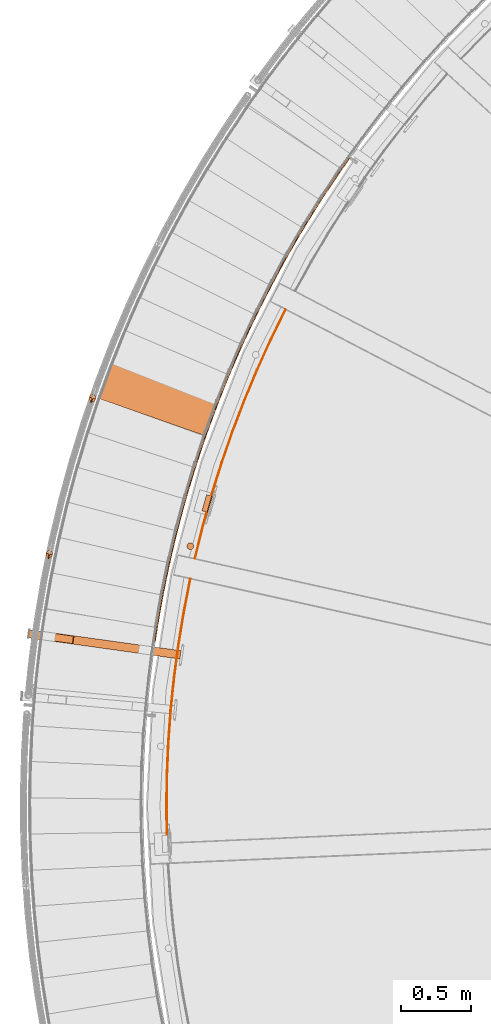
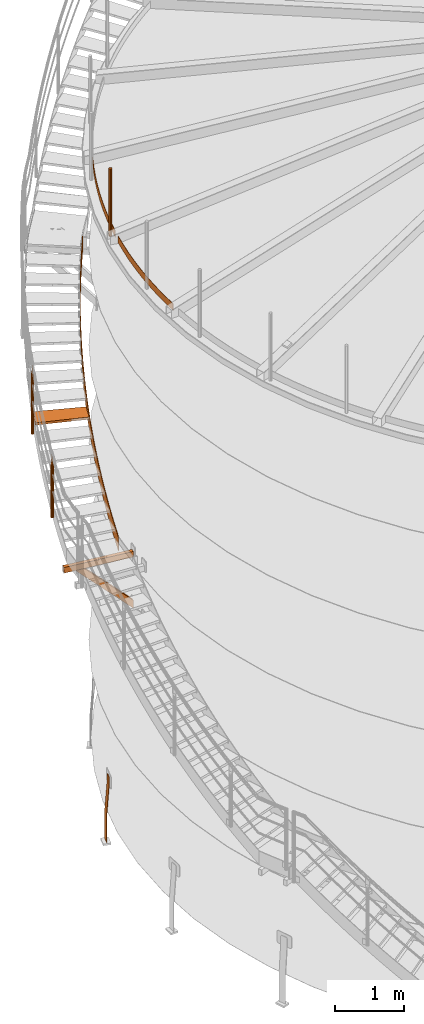
# One storey, part 25 of 126: 10 proxies.
"""IFC2X3 building model written with IfcOpenShell, lengths in millimetres."""

from ifc_helpers import new_model, si_unit, origin, origin_with_axes, place, context, project, spatial, faceted_brep, material, element, save


model = new_model("IFC2X3")

# Units and contexts
context_of_model_1 = context(None, 3, precision=0.1, world=origin())
context_of_model_2 = context(None, 3, precision=0.1, world=origin())
ifc_project = project(units=[si_unit("LENGTHUNIT", "METRE", prefix="MILLI"), si_unit("AREAUNIT", "SQUARE_METRE", prefix="CENTI"), si_unit("VOLUMEUNIT", "CUBIC_METRE", prefix="CENTI"), si_unit("MASSUNIT", "GRAM", prefix="KILO")], contexts=[context_of_model_1, context_of_model_2])

# Site, building, storey
site_placement = place(None, origin_with_axes())
site = spatial("IfcSite", under=ifc_project, at=site_placement, CompositionType="ELEMENT")
building_placement = place(site_placement, origin_with_axes())
building = spatial("IfcBuilding", under=site, at=building_placement, CompositionType="ELEMENT")
storey_placement = place(building_placement, origin_with_axes())
storey = spatial("IfcBuildingStorey", under=building, at=storey_placement, CompositionType="ELEMENT")

# Proxies
ifc_material_1 = material(Name="HOLZ")
proxy_1_placement = place(storey_placement, origin_with_axes())
element("IfcBuildingElementProxy", 1, at=proxy_1_placement, inside=storey, material=ifc_material_1, context=context_of_model_2, shape_type="Brep", body=[
    faceted_brep([(-215.7659, 11192.239, 6755.0438), (-225.2447, 11167.682, 6755.0438), (-234.6502, 11143.097, 6755.0438), (-243.9822, 11118.484, 6755.0438), (-253.2407, 11093.842, 6755.0438), (-262.4256, 11069.174, 6755.0438), (-271.5368, 11044.478, 6755.0438), (-280.5742, 11019.755, 6755.0438), (-289.5378, 10995.005, 6755.0438), (-298.4274, 10970.228, 6755.0438), (-307.2431, 10945.425, 6755.0438), (-315.9846, 10920.596, 6755.0438), (439.01, 10656.053, 6755.0438), (447.8478, 10681.142, 6755.0438), (456.7688, 10706.202, 6755.0438), (465.7729, 10731.232, 6755.0438), (474.86, 10756.232, 6755.0438), (484.03, 10781.202, 6755.0438), (493.2828, 10806.141, 6755.0438), (502.6183, 10831.049, 6755.0438), (512.0364, 10855.927, 6755.0438), (521.537, 10880.773, 6755.0438), (531.1199, 10905.587, 6755.0438), (-215.7659, 11192.239, 6715.0438), (531.1199, 10905.587, 6715.0438), (521.537, 10880.773, 6715.0438), (512.0364, 10855.927, 6715.0438), (502.6183, 10831.049, 6715.0438), (493.2828, 10806.141, 6715.0438), (484.03, 10781.202, 6715.0438), (474.86, 10756.232, 6715.0438), (465.7729, 10731.232, 6715.0438), (456.7688, 10706.202, 6715.0438), (447.8478, 10681.142, 6715.0438), (439.01, 10656.053, 6715.0438), (-315.9846, 10920.596, 6715.0438), (-307.2431, 10945.425, 6715.0438), (-298.4274, 10970.228, 6715.0438), (-289.5378, 10995.005, 6715.0438), (-280.5742, 11019.755, 6715.0438), (-271.5368, 11044.478, 6715.0438), (-262.4256, 11069.174, 6715.0438), (-253.2407, 11093.842, 6715.0438), (-243.9822, 11118.484, 6715.0438), (-234.6502, 11143.097, 6715.0438), (-225.2447, 11167.682, 6715.0438)], [[[0, 1, 2, 3, 4, 5, 6, 7, 8, 9, 10, 11, 12, 13, 14, 15, 16, 17, 18, 19, 20, 21, 22]], [[23, 24, 25, 26, 27, 28, 29, 30, 31, 32, 33, 34, 35, 36, 37, 38, 39, 40, 41, 42, 43, 44, 45]], [[0, 23, 45, 1]], [[1, 45, 44, 2]], [[2, 44, 43, 3]], [[3, 43, 42, 4]], [[4, 42, 41, 5]], [[5, 41, 40, 6]], [[6, 40, 39, 7]], [[7, 39, 38, 8]], [[8, 38, 37, 9]], [[9, 37, 36, 10]], [[10, 36, 35, 11]], [[11, 35, 34, 12]], [[12, 34, 33, 13]], [[13, 33, 32, 14]], [[14, 32, 31, 15]], [[15, 31, 30, 16]], [[16, 30, 29, 17]], [[17, 29, 28, 18]], [[18, 28, 27, 19]], [[19, 27, 26, 20]], [[20, 26, 25, 21]], [[21, 25, 24, 22]], [[22, 24, 23, 0]]]),
])
ifc_material_2 = material(Name="S235JRG2")
proxy_2_placement = place(storey_placement, origin_with_axes())
element("IfcBuildingElementProxy", 2, at=proxy_2_placement, inside=storey, material=ifc_material_2, context=context_of_model_2, shape_type="Brep", body=[
    faceted_brep([(-821.3165, 9206.5283, 5292.55), (-821.3165, 9206.5283, 5392.55), (-813.0231, 9265.9524, 5392.55), (-813.0231, 9265.9524, 5292.55), (-820.9018, 9209.4995, 5295.55), (-813.4378, 9262.9812, 5295.55), (-813.4378, 9262.9812, 5389.55), (-820.9018, 9209.4995, 5389.55), (271.1421, 9114.644, 5292.55), (262.8487, 9055.2199, 5292.55), (271.1421, 9114.644, 5392.55), (262.8487, 9055.2199, 5392.55), (263.2634, 9058.1911, 5389.55), (263.2634, 9058.1911, 5295.55), (270.7274, 9111.6728, 5389.55), (270.7274, 9111.6728, 5295.55)], [[[0, 1, 2, 3], [4, 5, 6, 7]], [[0, 3, 8, 9]], [[2, 10, 8, 3]], [[1, 11, 10, 2]], [[0, 9, 11, 1]], [[4, 7, 12, 13]], [[6, 14, 12, 7]], [[5, 15, 14, 6]], [[4, 13, 15, 5]], [[9, 8, 10, 11], [12, 14, 15, 13]]]),
])
proxy_3_placement = place(storey_placement, origin_with_axes())
element("IfcBuildingElementProxy", 3, at=proxy_3_placement, inside=storey, material=ifc_material_2, context=context_of_model_2, shape_type="Brep", body=[
    faceted_brep([(-643.7481, 9181.7465, 5292.55), (-635.4548, 9241.1706, 5292.55), (271.1421, 9114.644, 4377.1666), (262.8487, 9055.2199, 4377.1666), (-495.3909, 9221.6229, 5292.55), (271.1421, 9114.644, 4518.5879), (-503.6842, 9162.1989, 5292.55), (262.8487, 9055.2199, 4518.5879), (-639.1315, 9184.1313, 5292.55), (-507.4715, 9165.7565, 5292.55), (263.2634, 9058.1911, 4514.3453), (263.2634, 9058.1911, 4381.4092), (-500.0075, 9219.2382, 5292.55), (270.7274, 9111.6728, 4514.3453), (-631.6675, 9237.6129, 5292.55), (270.7274, 9111.6728, 4381.4092)], [[[0, 1, 2, 3]], [[1, 4, 5, 2]], [[4, 6, 7, 5]], [[0, 3, 7, 6]], [[8, 9, 10, 11]], [[9, 12, 13, 10]], [[12, 14, 15, 13]], [[8, 11, 15, 14]], [[1, 0, 6, 4], [8, 14, 12, 9]], [[3, 2, 5, 7], [10, 13, 15, 11]]]),
])
ifc_material_3 = material(Name="STAHL")
proxy_4_placement = place(storey_placement, origin_with_axes())
element("IfcBuildingElementProxy", 4, at=proxy_4_placement, inside=storey, material=ifc_material_3, Name="profile", context=context_of_model_2, shape_type="Brep", body=[
    faceted_brep([(489.3, 10219.0, 651.1), (488.6, 10216.6, 654.1), (496.3, 10214.4, 654.1), (497.0, 10216.8, 651.1), (497.5, 10218.6, 647.7), (489.8, 10220.8, 647.7), (497.8, 10219.7, 643.9), (490.1, 10221.9, 643.9), (497.9, 10220.0, 640.0), (497.9, 10220.0, 540.0), (461.4, 10230.5, 0.0), (461.4, 10230.5, -500.0), (453.7, 10232.7, -500.0), (453.7, 10232.7, 0.0), (490.3, 10222.2, 540.0), (490.3, 10222.2, 640.0), (466.5, 10110.3, 654.1), (458.8, 10112.5, 654.1), (458.1, 10110.1, 651.1), (465.8, 10107.9, 651.1), (465.3, 10106.1, 647.7), (457.6, 10108.3, 647.7), (465.0, 10105.0, 643.9), (457.3, 10107.3, 643.9), (464.9, 10104.7, 640.0), (457.2, 10106.9, 640.0), (457.2, 10106.9, 540.0), (420.6, 10117.4, 0.0), (420.6, 10117.4, -500.0), (428.3, 10115.2, -500.0), (428.3, 10115.2, 0.0), (464.9, 10104.7, 540.0), (469.3, 10120.2, 659.6), (470.4, 10123.9, 660.0), (492.4, 10200.8, 660.0), (493.5, 10204.6, 659.6), (485.8, 10206.8, 659.6), (484.7, 10203.0, 660.0), (462.7, 10126.1, 660.0), (461.6, 10122.4, 659.6), (460.6, 10118.8, 658.5), (468.3, 10116.5, 658.5), (459.6, 10115.4, 656.6), (467.3, 10113.2, 656.6), (494.5, 10208.2, 658.5), (486.9, 10210.4, 658.5), (495.5, 10211.5, 656.6), (487.8, 10213.7, 656.6)], [[[0, 1, 2, 3]], [[0, 3, 4, 5]], [[5, 4, 6, 7]], [[6, 8, 9, 10, 11, 12, 13, 14, 15, 7]], [[16, 17, 18, 19]], [[20, 19, 18, 21]], [[22, 20, 21, 23]], [[24, 22, 23, 25, 26, 27, 28, 29, 30, 31]], [[32, 33, 34, 35, 36, 37, 38, 39]], [[32, 39, 40, 41]], [[41, 40, 42, 43]], [[43, 42, 17, 16]], [[36, 35, 44, 45]], [[45, 44, 46, 47]], [[47, 46, 2, 1]], [[26, 25, 23, 21, 18, 17, 42, 40, 39, 38, 37, 36, 45, 47, 1, 0, 5, 7, 15, 14, 13, 12, 28, 27]], [[24, 31, 30, 29, 11, 10, 9, 8, 6, 4, 3, 2, 46, 44, 35, 34, 33, 32, 41, 43, 16, 19, 20, 22]], [[28, 12, 11, 29]]]),
])
proxy_5_placement = place(storey_placement, origin_with_axes())
element("IfcBuildingElementProxy", 5, at=proxy_5_placement, inside=storey, material=ifc_material_3, Name="profile", context=context_of_model_2, shape_type="Brep", body=[
    faceted_brep([(357.5, 9876.0, 11706.0), (357.5, 9876.0, 10506.0), (353.9, 9880.6, 10506.0), (353.9, 9880.6, 11706.0), (349.3, 9884.1, 10506.0), (349.3, 9884.1, 11706.0), (344.0, 9886.5, 10506.0), (344.0, 9886.5, 11706.0), (338.2, 9887.5, 10506.0), (338.2, 9887.5, 11706.0), (332.4, 9887.1, 10506.0), (332.4, 9887.1, 11706.0), (326.9, 9885.3, 10506.0), (326.9, 9885.3, 11706.0), (321.9, 9882.2, 10506.0), (321.9, 9882.2, 11706.0), (317.8, 9878.1, 10506.0), (317.8, 9878.1, 11706.0), (314.9, 9873.1, 10506.0), (314.9, 9873.1, 11706.0), (313.2, 9867.5, 10506.0), (313.2, 9867.5, 11706.0), (312.9, 9861.7, 10506.0), (312.9, 9861.7, 11706.0), (314.0, 9856.0, 10506.0), (314.0, 9856.0, 11706.0), (316.4, 9850.7, 10506.0), (316.4, 9850.7, 11706.0), (320.0, 9846.1, 11706.0), (320.0, 9846.1, 10506.0), (324.6, 9842.6, 11706.0), (324.6, 9842.6, 10506.0), (330.0, 9840.2, 11706.0), (330.0, 9840.2, 10506.0), (335.7, 9839.2, 11706.0), (335.7, 9839.2, 10506.0), (341.5, 9839.6, 11706.0), (341.5, 9839.6, 10506.0), (347.1, 9841.4, 11706.0), (347.1, 9841.4, 10506.0), (352.0, 9844.5, 11706.0), (352.0, 9844.5, 10506.0), (356.1, 9848.6, 11706.0), (356.1, 9848.6, 10506.0), (359.1, 9853.6, 11706.0), (359.1, 9853.6, 10506.0), (360.8, 9859.2, 11706.0), (360.8, 9859.2, 10506.0), (361.1, 9865.0, 11706.0), (361.1, 9865.0, 10506.0), (360.0, 9870.7, 11706.0), (360.0, 9870.7, 10506.0)], [[[0, 1, 2, 3]], [[3, 2, 4, 5]], [[5, 4, 6, 7]], [[7, 6, 8, 9]], [[9, 8, 10, 11]], [[11, 10, 12, 13]], [[13, 12, 14, 15]], [[15, 14, 16, 17]], [[17, 16, 18, 19]], [[19, 18, 20, 21]], [[21, 20, 22, 23]], [[23, 22, 24, 25]], [[25, 24, 26, 27]], [[28, 27, 26, 29]], [[30, 28, 29, 31]], [[32, 30, 31, 33]], [[34, 32, 33, 35]], [[36, 34, 35, 37]], [[38, 36, 37, 39]], [[40, 38, 39, 41]], [[42, 40, 41, 43]], [[44, 42, 43, 45]], [[46, 44, 45, 47]], [[48, 46, 47, 49]], [[50, 48, 49, 51]], [[0, 50, 51, 1]], [[34, 36, 38, 40, 42, 44, 46, 48, 50, 0, 3, 5, 7, 9, 11, 13, 15, 17, 19, 21, 23, 25, 27, 28, 30, 32]], [[35, 33, 31, 29, 26, 24, 22, 20, 18, 16, 14, 12, 10, 8, 6, 4, 2, 1, 51, 49, 47, 45, 43, 41, 39, 37]]]),
])
proxy_6_placement = place(storey_placement, origin_with_axes())
element("IfcBuildingElementProxy", 6, at=proxy_6_placement, inside=storey, material=ifc_material_3, Name="profile", context=context_of_model_2, shape_type="Brep", body=[
    faceted_brep([(367.7, 9775.5, 10516.0), (367.7, 9775.5, 10636.0), (424.9, 10006.4, 10636.0), (489.1, 10235.5, 10636.0), (560.3, 10462.6, 10636.0), (638.3, 10687.3, 10636.0), (723.1, 10909.6, 10636.0), (814.6, 11129.2, 10636.0), (912.7, 11346.0, 10636.0), (1017.3, 11559.7, 10636.0), (1017.3, 11559.7, 10516.0), (912.7, 11346.0, 10516.0), (814.6, 11129.2, 10516.0), (723.1, 10909.6, 10516.0), (638.3, 10687.3, 10516.0), (560.3, 10462.6, 10516.0), (489.1, 10235.5, 10516.0), (424.9, 10006.4, 10516.0), (372.6, 9774.4, 10636.0), (429.8, 10005.2, 10636.0), (493.9, 10234.1, 10636.0), (565.0, 10461.0, 10636.0), (643.0, 10685.6, 10636.0), (727.7, 10907.8, 10636.0), (819.1, 11127.3, 10636.0), (917.2, 11343.9, 10636.0), (1021.8, 11557.4, 10636.0), (372.6, 9774.4, 10516.0), (429.8, 10005.2, 10516.0), (493.9, 10234.1, 10516.0), (565.0, 10461.0, 10516.0), (643.0, 10685.6, 10516.0), (727.7, 10907.8, 10516.0), (819.1, 11127.3, 10516.0), (917.2, 11343.9, 10516.0), (1021.8, 11557.4, 10516.0)], [[[0, 1, 2, 3, 4, 5, 6, 7, 8, 9, 10, 11, 12, 13, 14, 15, 16, 17]], [[18, 19, 20, 21, 22, 23, 24, 25, 26, 9, 8, 7, 6, 5, 4, 3, 2, 1]], [[18, 27, 28, 29, 30, 31, 32, 33, 34, 35, 26, 25, 24, 23, 22, 21, 20, 19]], [[27, 0, 17, 16, 15, 14, 13, 12, 11, 10, 35, 34, 33, 32, 31, 30, 29, 28]], [[18, 1, 0, 27]], [[26, 35, 10, 9]]]),
])
proxy_7_placement = place(storey_placement, origin_with_axes())
element("IfcBuildingElementProxy", 7, at=proxy_7_placement, inside=storey, material=ifc_material_3, Name="profile", context=context_of_model_2, shape_type="Brep", body=[
    faceted_brep([(169.7, 7738.5, 10516.0), (169.7, 7738.5, 10636.0), (165.2, 7976.4, 10636.0), (167.9, 8214.3, 10636.0), (177.9, 8452.0, 10636.0), (195.1, 8689.3, 10636.0), (219.4, 8925.9, 10636.0), (251.0, 9161.8, 10636.0), (289.6, 9396.5, 10636.0), (335.4, 9630.0, 10636.0), (335.4, 9630.0, 10516.0), (289.6, 9396.5, 10516.0), (251.0, 9161.8, 10516.0), (219.4, 8925.9, 10516.0), (195.1, 8689.3, 10516.0), (177.9, 8452.0, 10516.0), (167.9, 8214.3, 10516.0), (165.2, 7976.4, 10516.0), (174.7, 7738.7, 10636.0), (170.2, 7976.4, 10636.0), (172.9, 8214.1, 10636.0), (182.9, 8451.7, 10636.0), (200.0, 8688.8, 10636.0), (224.4, 8925.4, 10636.0), (255.9, 9161.0, 10636.0), (294.5, 9395.6, 10636.0), (340.3, 9629.0, 10636.0), (174.7, 7738.7, 10516.0), (170.2, 7976.4, 10516.0), (172.9, 8214.1, 10516.0), (182.9, 8451.7, 10516.0), (200.0, 8688.8, 10516.0), (224.4, 8925.4, 10516.0), (255.9, 9161.0, 10516.0), (294.5, 9395.6, 10516.0), (340.3, 9629.0, 10516.0)], [[[0, 1, 2, 3, 4, 5, 6, 7, 8, 9, 10, 11, 12, 13, 14, 15, 16, 17]], [[1, 18, 19, 20, 21, 22, 23, 24, 25, 26, 9, 8, 7, 6, 5, 4, 3, 2]], [[18, 27, 28, 29, 30, 31, 32, 33, 34, 35, 26, 25, 24, 23, 22, 21, 20, 19]], [[0, 17, 16, 15, 14, 13, 12, 11, 10, 35, 34, 33, 32, 31, 30, 29, 28, 27]], [[18, 1, 0, 27]], [[26, 35, 10, 9]]]),
])
proxy_8_placement = place(storey_placement, origin_with_axes())
element("IfcBuildingElementProxy", 8, at=proxy_8_placement, inside=storey, material=ifc_material_2, context=context_of_model_2, shape_type="Brep", body=[
    faceted_brep([(78.4913, 9192.7233, 5401.4859), (88.3811, 9191.2414, 5401.4017), (86.7402, 9179.8803, 5392.9676), (76.7304, 9180.5312, 5392.4395), (88.3811, 9191.2414, 5649.5838), (86.7402, 9179.8803, 5641.1466), (78.4913, 9192.7233, 5649.6227), (76.7304, 9180.5312, 5640.5796), (91.5135, 9276.5967, 5463.8084), (101.387, 9275.0101, 5463.6977), (101.387, 9275.0101, 5711.893), (91.5135, 9276.5967, 5711.9319), (105.4232, 9360.3275, 5526.1253), (115.2793, 9358.6365, 5525.9993), (115.2793, 9358.6365, 5774.2023), (105.4232, 9360.3275, 5774.2412), (120.2188, 9443.9063, 5588.439), (130.0565, 9442.111, 5588.3041), (130.0565, 9442.111, 5836.5115), (120.2188, 9443.9063, 5836.5504), (135.8986, 9527.3237, 5650.7509), (145.7168, 9525.4243, 5650.6107), (145.7168, 9525.4243, 5898.8208), (135.8986, 9527.3237, 5898.8597), (152.461, 9610.5704, 5713.0616), (162.2584, 9608.5672, 5712.9184), (162.2584, 9608.5672, 5961.13), (152.461, 9610.5704, 5961.1689), (169.9039, 9693.6371, 5775.3718), (179.6796, 9691.5302, 5775.2268), (179.6796, 9691.5302, 6023.4393), (169.9039, 9693.6371, 6023.4782), (188.2256, 9776.5143, 5837.6815), (197.9784, 9774.3041, 5837.5355), (197.9784, 9774.3041, 6085.7485), (188.2256, 9776.5143, 6085.7874), (207.4239, 9859.1929, 5899.9911), (217.1527, 9856.8795, 5899.8444), (217.1527, 9856.8795, 6148.0578), (207.4239, 9859.1929, 6148.0967), (227.4966, 9941.6636, 5962.3005), (237.2004, 9939.2473, 5962.1535), (237.2004, 9939.2473, 6210.367), (227.4966, 9941.6636, 6210.4059), (248.4416, 10023.917, 6024.6099), (258.1193, 10021.398, 6024.4627), (258.1193, 10021.398, 6272.6763), (248.4416, 10023.917, 6272.7152), (270.2564, 10105.944, 6086.9192), (279.9069, 10103.323, 6086.7719), (279.9069, 10103.323, 6334.9855), (270.2564, 10105.944, 6335.0244), (292.9387, 10187.736, 6149.2284), (302.5608, 10185.012, 6149.0811), (302.5608, 10185.012, 6397.2948), (292.9387, 10187.736, 6397.3336), (316.4858, 10269.282, 6211.5377), (326.0786, 10266.457, 6211.3903), (326.0786, 10266.457, 6459.604), (316.4858, 10269.282, 6459.6429), (340.8952, 10350.575, 6273.847), (350.4575, 10347.648, 6273.6995), (350.4575, 10347.648, 6521.9132), (340.8952, 10350.575, 6521.9521), (366.1641, 10431.605, 6336.1562), (375.6949, 10428.577, 6336.0088), (375.6949, 10428.577, 6584.2225), (366.1641, 10431.605, 6584.2614), (392.2896, 10512.362, 6398.4655), (401.7878, 10509.234, 6398.318), (401.7878, 10509.234, 6646.5317), (392.2896, 10512.362, 6646.5706), (419.2689, 10592.839, 6460.7747), (428.7335, 10589.61, 6460.6273), (428.7335, 10589.61, 6708.841), (419.2689, 10592.839, 6708.8799), (447.0989, 10673.025, 6523.084), (456.5288, 10669.696, 6522.9365), (456.5288, 10669.696, 6771.1502), (447.0989, 10673.025, 6771.1891), (475.7765, 10752.912, 6585.3932), (485.1706, 10749.483, 6585.2458), (485.1706, 10749.483, 6833.4595), (475.7765, 10752.912, 6833.4984), (505.2985, 10832.49, 6647.7025), (514.6557, 10828.963, 6647.555), (514.6557, 10828.963, 6895.7687), (505.2985, 10832.49, 6895.8076), (535.6616, 10911.752, 6710.0117), (544.9809, 10908.125, 6709.8642), (544.9809, 10908.125, 6958.078), (535.6616, 10911.752, 6958.1169), (566.8623, 10990.688, 6772.321), (576.1427, 10986.963, 6772.1735), (576.1427, 10986.963, 7020.3872), (566.8623, 10990.688, 7020.4261), (598.8971, 11069.289, 6834.6302), (608.1376, 11065.465, 6834.4827), (608.1376, 11065.465, 7082.6965), (598.8971, 11069.289, 7082.7354), (631.7626, 11147.546, 6896.9395), (640.962, 11143.625, 6896.792), (640.962, 11143.625, 7145.0057), (631.7626, 11147.546, 7145.0446), (665.4549, 11225.451, 6959.2487), (674.6123, 11221.432, 6959.1012), (674.6123, 11221.432, 7207.315), (665.4549, 11225.451, 7207.3539), (699.9703, 11302.994, 7021.558), (709.0846, 11298.879, 7021.4105), (709.0846, 11298.879, 7269.6242), (699.9703, 11302.994, 7269.6631), (735.305, 11380.168, 7083.8672), (744.3752, 11375.957, 7083.7197), (744.3752, 11375.957, 7331.9335), (735.305, 11380.168, 7331.9724), (771.4549, 11456.963, 7146.1765), (780.48, 11452.656, 7146.029), (780.48, 11452.656, 7394.2427), (771.4549, 11456.963, 7394.2816), (808.416, 11533.371, 7208.4857), (817.395, 11528.969, 7208.3382), (817.395, 11528.969, 7456.552), (808.416, 11533.371, 7456.5909), (846.1842, 11609.384, 7270.795), (855.1161, 11604.887, 7270.6475), (855.1161, 11604.887, 7518.8612), (846.1842, 11609.384, 7518.9001), (884.7553, 11684.992, 7333.1042), (893.6391, 11680.4, 7332.9567), (893.6391, 11680.4, 7581.1705), (884.7553, 11684.992, 7581.2094), (924.1249, 11760.187, 7395.4134), (932.9595, 11755.502, 7395.266), (932.9595, 11755.502, 7643.4797), (924.1249, 11760.187, 7643.5186), (964.2885, 11834.962, 7457.7227), (973.0731, 11830.183, 7457.5752), (973.0731, 11830.183, 7705.789), (964.2885, 11834.962, 7705.8279), (1005.2418, 11909.307, 7520.0319), (1013.9752, 11904.435, 7519.8845), (1013.9752, 11904.435, 7768.0982), (1005.2418, 11909.307, 7768.1371), (1046.98, 11983.214, 7582.3412), (1055.6614, 11978.25, 7582.1937), (1055.6614, 11978.25, 7830.4075), (1046.98, 11983.214, 7830.4463), (1089.4986, 12056.674, 7644.6504), (1098.1269, 12051.619, 7644.503), (1098.1269, 12051.619, 7892.7167), (1089.4986, 12056.674, 7892.7556), (1132.7927, 12129.681, 7706.9597), (1141.367, 12124.535, 7706.8122), (1141.367, 12124.535, 7955.0259), (1132.7927, 12129.681, 7955.0648), (1176.8575, 12202.225, 7769.2689), (1185.3768, 12196.988, 7769.1215), (1185.3768, 12196.988, 8017.3352), (1176.8575, 12202.225, 8017.3741), (1221.6881, 12274.298, 7831.5782), (1230.1515, 12268.971, 7831.4307), (1230.1515, 12268.971, 8079.6444), (1221.6881, 12274.298, 8079.6833), (1267.2794, 12345.892, 7893.8874), (1275.6859, 12340.476, 7893.74), (1275.6859, 12340.476, 8141.9537), (1267.2794, 12345.892, 8141.9926), (1313.6263, 12417.0, 7956.1967), (1321.975, 12411.495, 7956.0492), (1321.975, 12411.495, 8204.2629), (1313.6263, 12417.0, 8204.3018), (1360.7236, 12487.613, 8018.5059), (1369.0135, 12482.02, 8018.3584), (1369.0135, 12482.02, 8266.5722), (1360.7236, 12487.613, 8266.6111), (1408.5661, 12557.723, 8080.8152), (1416.7963, 12552.043, 8080.6677), (1416.7963, 12552.043, 8328.8814), (1408.5661, 12557.723, 8328.9203), (1457.1483, 12627.322, 8143.1244), (1465.3179, 12621.555, 8142.9769), (1465.3179, 12621.555, 8391.1907), (1457.1483, 12627.322, 8391.2296), (1473.6414, 12650.425, 8163.9628), (1481.885, 12644.762, 8163.9349), (1481.885, 12644.762, 8412.1486), (1473.6414, 12650.425, 8412.0679)], [[[0, 1, 2, 3]], [[1, 4, 5, 2]], [[4, 6, 7, 5]], [[0, 3, 7, 6]], [[0, 8, 9, 1]], [[1, 9, 10, 4]], [[4, 10, 11, 6]], [[6, 11, 8, 0]], [[8, 12, 13, 9]], [[9, 13, 14, 10]], [[10, 14, 15, 11]], [[11, 15, 12, 8]], [[12, 16, 17, 13]], [[13, 17, 18, 14]], [[14, 18, 19, 15]], [[15, 19, 16, 12]], [[16, 20, 21, 17]], [[17, 21, 22, 18]], [[18, 22, 23, 19]], [[19, 23, 20, 16]], [[20, 24, 25, 21]], [[21, 25, 26, 22]], [[22, 26, 27, 23]], [[23, 27, 24, 20]], [[24, 28, 29, 25]], [[25, 29, 30, 26]], [[26, 30, 31, 27]], [[27, 31, 28, 24]], [[28, 32, 33, 29]], [[29, 33, 34, 30]], [[30, 34, 35, 31]], [[31, 35, 32, 28]], [[32, 36, 37, 33]], [[33, 37, 38, 34]], [[34, 38, 39, 35]], [[35, 39, 36, 32]], [[36, 40, 41, 37]], [[37, 41, 42, 38]], [[38, 42, 43, 39]], [[39, 43, 40, 36]], [[40, 44, 45, 41]], [[41, 45, 46, 42]], [[42, 46, 47, 43]], [[43, 47, 44, 40]], [[44, 48, 49, 45]], [[45, 49, 50, 46]], [[46, 50, 51, 47]], [[47, 51, 48, 44]], [[48, 52, 53, 49]], [[49, 53, 54, 50]], [[50, 54, 55, 51]], [[51, 55, 52, 48]], [[52, 56, 57, 53]], [[53, 57, 58, 54]], [[54, 58, 59, 55]], [[55, 59, 56, 52]], [[56, 60, 61, 57]], [[57, 61, 62, 58]], [[58, 62, 63, 59]], [[59, 63, 60, 56]], [[60, 64, 65, 61]], [[61, 65, 66, 62]], [[62, 66, 67, 63]], [[63, 67, 64, 60]], [[64, 68, 69, 65]], [[65, 69, 70, 66]], [[66, 70, 71, 67]], [[67, 71, 68, 64]], [[68, 72, 73, 69]], [[69, 73, 74, 70]], [[70, 74, 75, 71]], [[71, 75, 72, 68]], [[72, 76, 77, 73]], [[73, 77, 78, 74]], [[74, 78, 79, 75]], [[75, 79, 76, 72]], [[76, 80, 81, 77]], [[77, 81, 82, 78]], [[78, 82, 83, 79]], [[79, 83, 80, 76]], [[80, 84, 85, 81]], [[81, 85, 86, 82]], [[82, 86, 87, 83]], [[83, 87, 84, 80]], [[84, 88, 89, 85]], [[85, 89, 90, 86]], [[86, 90, 91, 87]], [[87, 91, 88, 84]], [[88, 92, 93, 89]], [[89, 93, 94, 90]], [[90, 94, 95, 91]], [[91, 95, 92, 88]], [[92, 96, 97, 93]], [[93, 97, 98, 94]], [[94, 98, 99, 95]], [[95, 99, 96, 92]], [[96, 100, 101, 97]], [[97, 101, 102, 98]], [[98, 102, 103, 99]], [[99, 103, 100, 96]], [[100, 104, 105, 101]], [[101, 105, 106, 102]], [[102, 106, 107, 103]], [[103, 107, 104, 100]], [[104, 108, 109, 105]], [[105, 109, 110, 106]], [[106, 110, 111, 107]], [[107, 111, 108, 104]], [[108, 112, 113, 109]], [[109, 113, 114, 110]], [[110, 114, 115, 111]], [[111, 115, 112, 108]], [[112, 116, 117, 113]], [[113, 117, 118, 114]], [[114, 118, 119, 115]], [[115, 119, 116, 112]], [[116, 120, 121, 117]], [[117, 121, 122, 118]], [[118, 122, 123, 119]], [[119, 123, 120, 116]], [[120, 124, 125, 121]], [[121, 125, 126, 122]], [[122, 126, 127, 123]], [[123, 127, 124, 120]], [[124, 128, 129, 125]], [[125, 129, 130, 126]], [[126, 130, 131, 127]], [[127, 131, 128, 124]], [[128, 132, 133, 129]], [[129, 133, 134, 130]], [[130, 134, 135, 131]], [[131, 135, 132, 128]], [[132, 136, 137, 133]], [[133, 137, 138, 134]], [[134, 138, 139, 135]], [[135, 139, 136, 132]], [[136, 140, 141, 137]], [[137, 141, 142, 138]], [[138, 142, 143, 139]], [[139, 143, 140, 136]], [[140, 144, 145, 141]], [[141, 145, 146, 142]], [[142, 146, 147, 143]], [[143, 147, 144, 140]], [[144, 148, 149, 145]], [[145, 149, 150, 146]], [[146, 150, 151, 147]], [[147, 151, 148, 144]], [[148, 152, 153, 149]], [[149, 153, 154, 150]], [[150, 154, 155, 151]], [[151, 155, 152, 148]], [[152, 156, 157, 153]], [[153, 157, 158, 154]], [[154, 158, 159, 155]], [[155, 159, 156, 152]], [[156, 160, 161, 157]], [[157, 161, 162, 158]], [[158, 162, 163, 159]], [[159, 163, 160, 156]], [[160, 164, 165, 161]], [[161, 165, 166, 162]], [[162, 166, 167, 163]], [[163, 167, 164, 160]], [[164, 168, 169, 165]], [[165, 169, 170, 166]], [[166, 170, 171, 167]], [[167, 171, 168, 164]], [[168, 172, 173, 169]], [[169, 173, 174, 170]], [[170, 174, 175, 171]], [[171, 175, 172, 168]], [[172, 176, 177, 173]], [[173, 177, 178, 174]], [[174, 178, 179, 175]], [[175, 179, 176, 172]], [[176, 180, 181, 177]], [[177, 181, 182, 178]], [[178, 182, 183, 179]], [[179, 183, 180, 176]], [[180, 184, 185, 181]], [[181, 185, 186, 182]], [[182, 186, 187, 183]], [[180, 183, 187, 184]], [[2, 5, 7, 3]], [[184, 187, 186, 185]]]),
])
ifc_material_4 = material(Name="1.4462")
proxy_9_placement = place(storey_placement, origin_with_axes())
element("IfcBuildingElementProxy", 9, at=proxy_9_placement, inside=storey, material=ifc_material_4, Name="Pfosten", context=context_of_model_2, shape_type="Brep", body=[
    faceted_brep([(-677.6412, 9783.0804, 6805.2549), (-688.8418, 9788.632, 6805.2549), (-688.8418, 9788.632, 5876.3986), (-677.6412, 9783.0804, 5876.3976), (-695.766, 9799.0402, 6805.2549), (-695.766, 9799.0402, 5876.4012), (-696.5585, 9811.516, 6805.2549), (-696.5585, 9811.516, 5876.4049), (-691.0068, 9822.7166, 6805.2549), (-691.0068, 9822.7166, 5876.4085), (-680.5987, 9829.6408, 6805.2549), (-680.5987, 9829.6408, 5876.4111), (-668.1229, 9830.4332, 6805.2549), (-668.1229, 9830.4332, 5876.4121), (-656.9223, 9824.8816, 6805.2549), (-656.9223, 9824.8816, 5876.4111), (-649.9981, 9814.4734, 6805.2549), (-649.9981, 9814.4734, 5876.4085), (-649.2056, 9801.9976, 6805.2549), (-649.2056, 9801.9976, 5876.4049), (-654.7573, 9790.797, 6805.2549), (-654.7573, 9790.797, 5876.4012), (-665.1654, 9783.8728, 6805.2549), (-665.1654, 9783.8728, 5876.3986), (-652.367, 9813.6746, 6805.2549), (-658.5744, 9823.0053, 6805.2549), (-658.5744, 9823.0053, 5876.4105), (-652.367, 9813.6746, 5876.4081), (-668.6155, 9827.9822, 6805.2549), (-668.6155, 9827.9822, 5876.4113), (-679.7998, 9827.2718, 6805.2549), (-679.7998, 9827.2718, 5876.4105), (-689.1306, 9821.0644, 6805.2549), (-689.1306, 9821.0644, 5876.4081), (-694.1075, 9811.0233, 6805.2549), (-694.1075, 9811.0233, 5876.4049), (-693.3971, 9799.839, 6805.2549), (-693.3971, 9799.839, 5876.4016), (-687.1897, 9790.5083, 6805.2549), (-687.1897, 9790.5083, 5876.3992), (-677.1486, 9785.5314, 6805.2549), (-677.1486, 9785.5314, 5876.3984), (-665.9642, 9786.2418, 6805.2549), (-665.9642, 9786.2418, 5876.3992), (-656.6335, 9792.4492, 6805.2549), (-656.6335, 9792.4492, 5876.4016), (-651.6566, 9802.4903, 6805.2549), (-651.6566, 9802.4903, 5876.4049), (-680.0766, 9770.965, 6853.5549), (-681.6654, 9772.0312, 6853.5549), (-682.0349, 9773.9086, 6853.5549), (-675.333, 9807.2495, 6853.5549), (-668.6312, 9840.5903, 6853.5549), (-667.5649, 9842.1791, 6853.5549), (-665.6875, 9842.5486, 6853.5549), (-664.0987, 9841.4824, 6853.5549), (-663.7292, 9839.605, 6853.5549), (-670.4311, 9806.2641, 6853.5549), (-677.1329, 9772.9233, 6853.5549), (-678.1992, 9771.3345, 6853.5549), (-665.9841, 9840.0582, 6853.5549), (-666.0137, 9840.2084, 6853.5549), (-666.1408, 9840.2937, 6853.5549), (-666.291, 9840.2642, 6853.5549), (-666.3763, 9840.1371, 6853.5549), (-673.0781, 9806.7962, 6853.5549), (-679.78, 9773.4554, 6853.5549), (-679.7504, 9773.3052, 6853.5549), (-679.6233, 9773.2199, 6853.5549), (-679.4731, 9773.2494, 6853.5549), (-679.3878, 9773.3765, 6853.5549), (-672.686, 9806.7174, 6853.5549), (-680.0766, 9770.965, 6924.6782), (-681.6654, 9772.0312, 6925.1941), (-682.0349, 9773.9086, 6926.4397), (-675.333, 9807.2495, 6950.4022), (-668.6312, 9840.5903, 6974.3648), (-667.5649, 9842.1791, 6975.6104), (-665.6875, 9842.5486, 6976.1263), (-664.0987, 9841.4824, 6975.6104), (-663.7292, 9839.605, 6974.3648), (-670.4311, 9806.2641, 6950.4022), (-677.1329, 9772.9233, 6926.4397), (-678.1992, 9771.3345, 6925.1941), (-665.9841, 9840.0582, 6974.3648), (-666.0137, 9840.2084, 6974.4644), (-666.1408, 9840.2937, 6974.5057), (-666.291, 9840.2642, 6974.4644), (-666.3763, 9840.1371, 6974.3648), (-673.0781, 9806.7962, 6950.4022), (-679.78, 9773.4554, 6926.4397), (-679.7504, 9773.3052, 6926.3401), (-679.6233, 9773.2199, 6926.2988), (-679.4731, 9773.2494, 6926.3401), (-679.3878, 9773.3765, 6926.4397), (-672.686, 9806.7174, 6950.4022)], [[[0, 1, 2, 3]], [[1, 4, 5, 2]], [[4, 6, 7, 5]], [[6, 8, 9, 7]], [[8, 10, 11, 9]], [[10, 12, 13, 11]], [[12, 14, 15, 13]], [[14, 16, 17, 15]], [[16, 18, 19, 17]], [[18, 20, 21, 19]], [[20, 22, 23, 21]], [[0, 3, 23, 22]], [[24, 25, 26, 27]], [[25, 28, 29, 26]], [[28, 30, 31, 29]], [[30, 32, 33, 31]], [[32, 34, 35, 33]], [[34, 36, 37, 35]], [[36, 38, 39, 37]], [[38, 40, 41, 39]], [[40, 42, 43, 41]], [[42, 44, 45, 43]], [[44, 46, 47, 45]], [[24, 27, 47, 46]], [[0, 48, 49, 1]], [[1, 49, 50, 4]], [[4, 50, 51, 6]], [[6, 51, 52, 8]], [[8, 52, 53, 10]], [[10, 53, 54, 12]], [[12, 54, 55, 14]], [[14, 55, 56, 16]], [[16, 56, 57, 18]], [[18, 57, 58, 20]], [[20, 58, 59, 22]], [[22, 59, 48, 0]], [[24, 60, 61, 25]], [[25, 61, 62, 28]], [[28, 62, 63, 30]], [[30, 63, 64, 32]], [[32, 64, 65, 34]], [[34, 65, 66, 36]], [[36, 66, 67, 38]], [[38, 67, 68, 40]], [[40, 68, 69, 42]], [[42, 69, 70, 44]], [[44, 70, 71, 46]], [[46, 71, 60, 24]], [[48, 72, 73, 49]], [[49, 73, 74, 50]], [[50, 74, 75, 51]], [[51, 75, 76, 52]], [[52, 76, 77, 53]], [[53, 77, 78, 54]], [[54, 78, 79, 55]], [[55, 79, 80, 56]], [[56, 80, 81, 57]], [[57, 81, 82, 58]], [[58, 82, 83, 59]], [[48, 59, 83, 72]], [[60, 84, 85, 61]], [[61, 85, 86, 62]], [[62, 86, 87, 63]], [[63, 87, 88, 64]], [[64, 88, 89, 65]], [[65, 89, 90, 66]], [[66, 90, 91, 67]], [[67, 91, 92, 68]], [[68, 92, 93, 69]], [[69, 93, 94, 70]], [[70, 94, 95, 71]], [[60, 71, 95, 84]], [[7, 9, 11, 13, 15, 17, 19, 21, 23, 3, 2, 5], [26, 29, 31, 33, 35, 37, 39, 41, 43, 45, 47, 27]], [[74, 73, 72, 83, 82, 81, 80, 79, 78, 77, 76, 75], [84, 95, 94, 93, 92, 91, 90, 89, 88, 87, 86, 85]]]),
])
proxy_10_placement = place(storey_placement, origin_with_axes())
element("IfcBuildingElementProxy", 10, at=proxy_10_placement, inside=storey, material=ifc_material_4, Name="Pfosten", context=context_of_model_2, shape_type="Brep", body=[
    faceted_brep([(-371.2296, 10901.164, 7622.8008), (-381.5954, 10908.151, 7622.8008), (-381.5954, 10908.151, 6578.9446), (-371.2296, 10901.164, 6578.9436), (-387.0788, 10919.386, 7622.8008), (-387.0788, 10919.386, 6578.9472), (-386.2104, 10931.856, 7622.8008), (-386.2104, 10931.856, 6578.9508), (-379.2229, 10942.222, 7622.8008), (-379.2229, 10942.222, 6578.9545), (-367.9887, 10947.705, 7622.8008), (-367.9887, 10947.705, 6578.9571), (-355.518, 10946.837, 7622.8008), (-355.518, 10946.837, 6578.9581), (-345.1522, 10939.85, 7622.8008), (-345.1522, 10939.85, 6578.9571), (-339.6688, 10928.615, 7622.8008), (-339.6688, 10928.615, 6578.9545), (-340.5372, 10916.145, 7622.8008), (-340.5372, 10916.145, 6578.9508), (-347.5247, 10905.779, 7622.8008), (-347.5247, 10905.779, 6578.9472), (-358.7589, 10900.296, 7622.8008), (-358.7589, 10900.296, 6578.9446), (-342.1228, 10928.138, 7622.8008), (-347.0385, 10938.209, 7622.8008), (-347.0385, 10938.209, 6578.9565), (-342.1228, 10928.138, 6578.9541), (-356.3312, 10944.473, 7622.8008), (-356.3312, 10944.473, 6578.9573), (-367.511, 10945.252, 7622.8008), (-367.511, 10945.252, 6578.9565), (-377.5822, 10940.336, 7622.8008), (-377.5822, 10940.336, 6578.9541), (-383.8463, 10931.043, 7622.8008), (-383.8463, 10931.043, 6578.9508), (-384.6248, 10919.863, 7622.8008), (-384.6248, 10919.863, 6578.9476), (-379.7091, 10909.792, 7622.8008), (-379.7091, 10909.792, 6578.9452), (-370.4164, 10903.528, 7622.8008), (-370.4164, 10903.528, 6578.9443), (-359.2366, 10902.75, 7622.8008), (-359.2366, 10902.75, 6578.9452), (-349.1654, 10907.665, 7622.8008), (-349.1654, 10907.665, 6578.9476), (-342.9013, 10916.958, 7622.8008), (-342.9013, 10916.958, 6578.9508), (-375.2495, 10889.478, 7671.1008), (-376.6829, 10890.746, 7671.1008), (-376.8003, 10892.656, 7671.1008), (-365.7378, 10924.814, 7671.1008), (-354.6754, 10956.972, 7671.1008), (-353.4079, 10958.405, 7671.1008), (-351.4981, 10958.523, 7671.1008), (-350.0647, 10957.255, 7671.1008), (-349.9473, 10955.345, 7671.1008), (-361.0098, 10923.187, 7671.1008), (-372.0723, 10891.029, 7671.1008), (-373.3397, 10889.596, 7671.1008), (-352.1222, 10956.094, 7671.1008), (-352.1316, 10956.246, 7671.1008), (-352.2463, 10956.348, 7671.1008), (-352.3991, 10956.338, 7671.1008), (-352.5004, 10956.224, 7671.1008), (-363.5629, 10924.066, 7671.1008), (-374.6254, 10891.907, 7671.1008), (-374.616, 10891.755, 7671.1008), (-374.5013, 10891.653, 7671.1008), (-374.3486, 10891.663, 7671.1008), (-374.2472, 10891.777, 7671.1008), (-363.1847, 10923.935, 7671.1008), (-375.2495, 10889.478, 7742.3625), (-376.6829, 10890.746, 7742.8779), (-376.8003, 10892.656, 7744.1221), (-365.7378, 10924.814, 7768.0574), (-354.6754, 10956.972, 7791.9927), (-353.4079, 10958.405, 7793.2369), (-351.4981, 10958.523, 7793.7523), (-350.0647, 10957.255, 7793.2369), (-349.9473, 10955.345, 7791.9927), (-361.0098, 10923.187, 7768.0574), (-372.0723, 10891.029, 7744.1221), (-373.3397, 10889.596, 7742.8779), (-352.1222, 10956.094, 7791.9927), (-352.1316, 10956.246, 7792.0922), (-352.2463, 10956.348, 7792.1335), (-352.3991, 10956.338, 7792.0922), (-352.5004, 10956.224, 7791.9927), (-363.5629, 10924.066, 7768.0574), (-374.6254, 10891.907, 7744.1221), (-374.616, 10891.755, 7744.0225), (-374.5013, 10891.653, 7743.9813), (-374.3486, 10891.663, 7744.0225), (-374.2472, 10891.777, 7744.1221), (-363.1847, 10923.935, 7768.0574)], [[[0, 1, 2, 3]], [[1, 4, 5, 2]], [[4, 6, 7, 5]], [[6, 8, 9, 7]], [[8, 10, 11, 9]], [[10, 12, 13, 11]], [[12, 14, 15, 13]], [[14, 16, 17, 15]], [[16, 18, 19, 17]], [[18, 20, 21, 19]], [[20, 22, 23, 21]], [[0, 3, 23, 22]], [[24, 25, 26, 27]], [[25, 28, 29, 26]], [[28, 30, 31, 29]], [[30, 32, 33, 31]], [[32, 34, 35, 33]], [[34, 36, 37, 35]], [[36, 38, 39, 37]], [[38, 40, 41, 39]], [[40, 42, 43, 41]], [[42, 44, 45, 43]], [[44, 46, 47, 45]], [[24, 27, 47, 46]], [[0, 48, 49, 1]], [[1, 49, 50, 4]], [[4, 50, 51, 6]], [[6, 51, 52, 8]], [[8, 52, 53, 10]], [[10, 53, 54, 12]], [[12, 54, 55, 14]], [[14, 55, 56, 16]], [[16, 56, 57, 18]], [[18, 57, 58, 20]], [[20, 58, 59, 22]], [[22, 59, 48, 0]], [[24, 60, 61, 25]], [[25, 61, 62, 28]], [[28, 62, 63, 30]], [[30, 63, 64, 32]], [[32, 64, 65, 34]], [[34, 65, 66, 36]], [[36, 66, 67, 38]], [[38, 67, 68, 40]], [[40, 68, 69, 42]], [[42, 69, 70, 44]], [[44, 70, 71, 46]], [[46, 71, 60, 24]], [[48, 72, 73, 49]], [[49, 73, 74, 50]], [[50, 74, 75, 51]], [[51, 75, 76, 52]], [[52, 76, 77, 53]], [[53, 77, 78, 54]], [[54, 78, 79, 55]], [[55, 79, 80, 56]], [[56, 80, 81, 57]], [[57, 81, 82, 58]], [[58, 82, 83, 59]], [[48, 59, 83, 72]], [[60, 84, 85, 61]], [[61, 85, 86, 62]], [[62, 86, 87, 63]], [[63, 87, 88, 64]], [[64, 88, 89, 65]], [[65, 89, 90, 66]], [[66, 90, 91, 67]], [[67, 91, 92, 68]], [[68, 92, 93, 69]], [[69, 93, 94, 70]], [[70, 94, 95, 71]], [[60, 71, 95, 84]], [[7, 9, 11, 13, 15, 17, 19, 21, 23, 3, 2, 5], [26, 29, 31, 33, 35, 37, 39, 41, 43, 45, 47, 27]], [[74, 73, 72, 83, 82, 81, 80, 79, 78, 77, 76, 75], [84, 95, 94, 93, 92, 91, 90, 89, 88, 87, 86, 85]]]),
])

save(model, "model.ifc")
